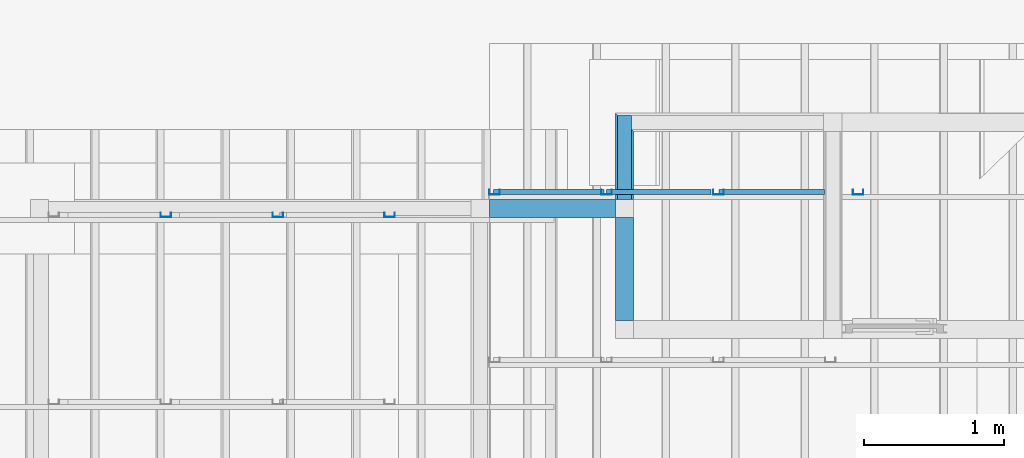
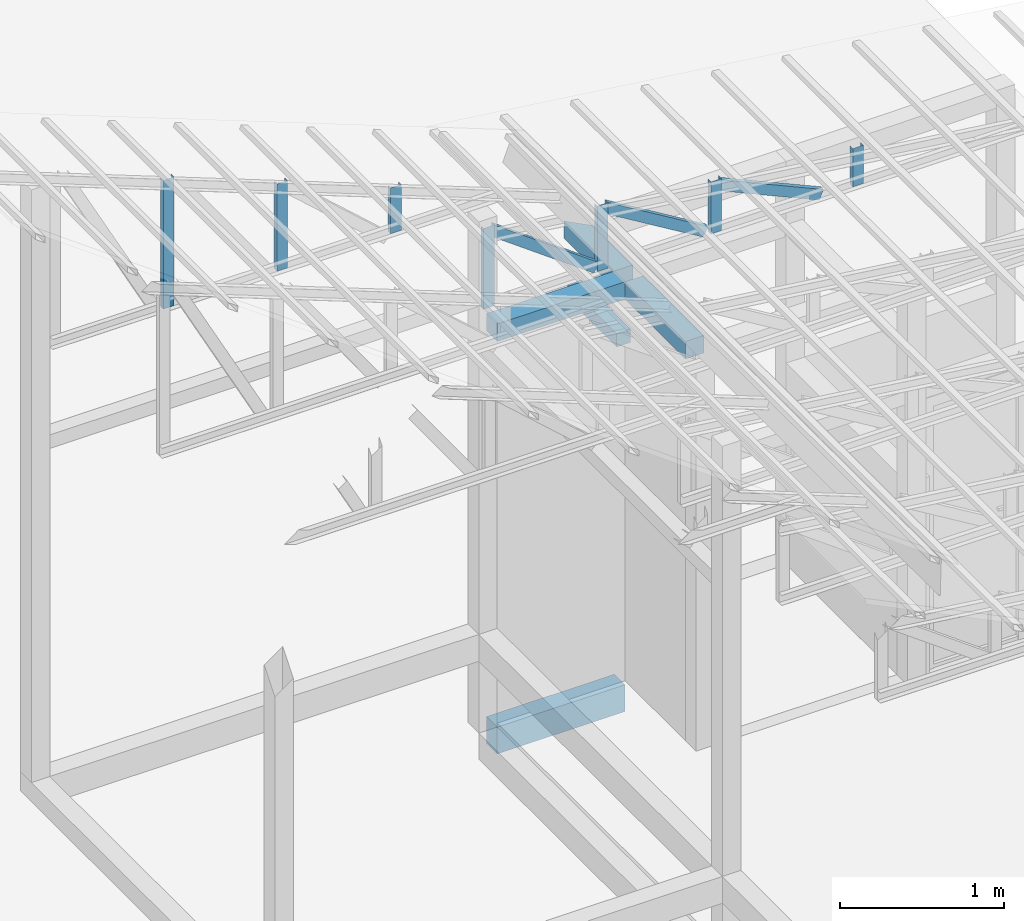
# One storey, part 19 of 22: 10 members, 5 beams, 2 elements without a shape of their own.
"""IFC4 building model written with IfcOpenShell, lengths in millimetres."""

from ifc_helpers import new_model, entity, si_unit, converted_unit, frame, origin_with_axes, origin_2d_with_axis, place, context, subcontext, project, spatial, indexed_curve, rectangle, c_section, outline, extrude, clip, halfspace, material, material_profile, profile_set, profile_usage, type_object, element, aggregate, save


model = new_model("IFC4")

# Units and contexts
model_context = context("Model", 3, precision=1e-05, world=origin_with_axes())
plan_context = context("Plan", 2, precision=1e-05, world=origin_2d_with_axis())
body_context = subcontext(model_context, "Body", "Model", "MODEL_VIEW")
ifc_project = project(units=[si_unit("VOLUMEUNIT", "CUBIC_METRE"), si_unit("LENGTHUNIT", "METRE", prefix="MILLI"), si_unit("AREAUNIT", "SQUARE_METRE"), converted_unit("PLANEANGLEUNIT", "degree", entity("IfcReal", 0.0174532925199433), si_unit("PLANEANGLEUNIT", "RADIAN"), dimensions=[0, 0, 0, 0, 0, 0, 0])], contexts=[model_context, plan_context])

# Site, building, storey
site_placement = place(None, origin_with_axes())
site = spatial("IfcSite", under=ifc_project, at=site_placement)
building_placement = place(site_placement, origin_with_axes())
building = spatial("IfcBuilding", under=site, at=building_placement, Name="2")
storey_placement = place(building_placement, frame((0.0, 0.0, 200.000002980232), z_axis=(0.0, 0.0, 1.0), x_axis=(1.0, 0.0, 0.0)))
storey = spatial("IfcBuildingStorey", under=building, at=storey_placement)

# Beams
ifc_material_1 = material(Name="Concrete")
ifc_material_profile_1 = material_profile(ifc_material_1, outline(indexed_curve([(-65.0, 99.9999923706055), (65.0, 99.9999923706055), (65.0, -99.9999923706055), (-65.0, -99.9999923706055), (-65.0, 99.9999923706055)])))
ifc_profile_set_1 = profile_set([ifc_material_profile_1])
ifc_profile_usage_1 = profile_usage(ifc_profile_set_1, cardinal=2)
beam_type_1 = type_object("IfcBeamType", PredefinedType="BEAM", material=ifc_profile_set_1)
beam_1_placement = place(storey_placement, frame((-3035.00008583069, 17300.0011444092, -200.000066923081), z_axis=(-0.99999999999995, 4.37114096030178e-08, 3.13916473260163e-07), x_axis=(-4.37113882867378e-08, -0.999999999999997, 5.96046589862452e-08)))
element("IfcBeam", 1, at=beam_1_placement, inside=storey, type_object=beam_type_1, material=ifc_profile_usage_1, Name="Beam", PredefinedType="BEAM", context=body_context, shape_type="SweptSolid", body=[
    extrude(outline(indexed_curve([(-65.0, 99.9999923706055), (65.0, 99.9999923706055), (65.0, -99.9999923706055), (-65.0, -99.9999923706055), (-65.0, 99.9999923706055)])), frame((0.0, 100.0, 0.0), z_axis=(0.0, 0.0, 1.0), x_axis=(1.0, 0.0, 0.0)), (0.0, 0.0, 1.0), 899.993908384733),
])
ifc_material_profile_2 = material_profile(ifc_material_1, rectangle(XDim=130.000015258789, YDim=130.000015258789))
ifc_profile_set_2 = profile_set([ifc_material_profile_2])
ifc_profile_usage_2 = profile_usage(ifc_profile_set_2, cardinal=9)
beam_type_2 = type_object("IfcBeamType", Name="Ring", PredefinedType="BEAM", material=ifc_profile_set_2)
beam_2_placement = place(storey_placement, frame((-3034.97314453125, 17979.9995422363, 3000.00028312206), z_axis=(0.0, -0.999999999999997, 7.54978986586412e-08), x_axis=(1.0, 0.0, 0.0)))
element("IfcBeam", 2, at=beam_2_placement, inside=storey, type_object=beam_type_2, material=ifc_profile_usage_2, Name="Beam", context=body_context, shape_type="Clipping", body=[
    clip(extrude(rectangle(XDim=130.000015258789, YDim=130.000015258789), frame((65.0000076293945, -65.0000076293945, 0.0), z_axis=(0.0, 0.0, 1.0), x_axis=(1.0, 0.0, 0.0)), (0.0, 0.0, 1.0), 615.009303022594), halfspace(frame((0.0, -3200.00171661377, -0.0019073486328125), z_axis=(0.707103550434113, 1.12382778638676e-08, -0.707110106945038), x_axis=(1.58933975893178e-08, -1.0, 0.0)), False)),
])
ifc_profile_usage_3 = profile_usage(ifc_profile_set_2, cardinal=9)
beam_3_placement = place(storey_placement, frame((-3034.97314453125, 17364.990234375, 3000.00028312206), z_axis=(-0.999999999999962, -1.94707164287728e-07, 1.94707178498585e-07), x_axis=(1.94707178498587e-07, -0.999999999999974, 1.19209289550778e-07)))
element("IfcBeam", 3, at=beam_3_placement, inside=storey, type_object=beam_type_2, material=ifc_profile_usage_3, Name="Beam", context=body_context, shape_type="SweptSolid", body=[
    extrude(rectangle(XDim=130.000015258789, YDim=130.000015258789), frame((65.0000076293945, -65.0000076293945, 0.0), z_axis=(0.0, 0.0, 1.0), x_axis=(1.0, 0.0, 0.0)), (0.0, 0.0, 1.0), 900.024405784302),
])
ifc_profile_usage_4 = profile_usage(ifc_profile_set_2, cardinal=9)
beam_4_placement = place(storey_placement, frame((-3035.00008583069, 17234.9987030029, 3000.00028312206), z_axis=(0.0, -0.999999999999997, 7.54978986586412e-08), x_axis=(1.0, 0.0, 0.0)))
element("IfcBeam", 4, at=beam_4_placement, inside=storey, type_object=beam_type_2, material=ifc_profile_usage_4, Name="Beam", context=body_context, shape_type="SweptSolid", body=[
    extrude(rectangle(XDim=130.000015258789, YDim=130.000015258789), frame((65.0000076293945, -65.0000076293945, 0.0), z_axis=(0.0, 0.0, 1.0), x_axis=(1.0, 0.0, 0.0)), (0.0, 0.0, 1.0), 734.998722205057),
])

# Assembly, members
assembly_1_placement = place(storey_placement, frame((-1561.45393848419, 6600.0657081604, 3019.63977515697), z_axis=(0.0, 0.0, 1.0), x_axis=(1.0, 0.0, 0.0)))
assembly_1 = element("IfcElementAssembly", 5, at=assembly_1_placement, inside=storey, Name="K1")
ifc_material_2 = material(Name="STEEL")
ifc_material_profile_3 = material_profile(ifc_material_2, c_section(Depth=75.0, Width=35.0, WallThickness=1.0, Girth=1.0, kind="CURVE"))
ifc_profile_set_3 = profile_set([ifc_material_profile_3])
ifc_profile_usage_5 = profile_usage(ifc_profile_set_3, cardinal=9)
member_type = type_object("IfcMemberType", Name="C75", PredefinedType="CHORD", material=ifc_profile_set_3)
member_1_placement = place(assembly_1_placement, frame((-2299.51107501984, 10798.9325523376, 592.46301651001), z_axis=(-8.7422719730052e-08, 3.25841369885875e-07, -0.999999999999943), x_axis=(1.62920684942936e-07, 0.999999999999934, 3.25841369885871e-07)))
member_1 = element("IfcMember", 6, at=member_1_placement, type_object=member_type, material=ifc_profile_usage_5, Name="Member", context=body_context, shape_type="SweptSolid", body=[
    extrude(c_section(Depth=75.0, Width=35.0, WallThickness=1.0, Girth=1.0, kind="CURVE"), frame((17.5, -37.5, 0.0), z_axis=(0.0, 0.0, 1.0), x_axis=(1.0, 0.0, 0.0)), (0.0, 0.0, 1.0), 601.479041515268),
])
ifc_profile_usage_6 = profile_usage(ifc_profile_set_3, cardinal=9)
member_2_placement = place(assembly_1_placement, frame((-1499.51112270355, 10798.9325523376, 479.381561279297), z_axis=(-8.7422719730052e-08, 3.25841369885875e-07, -0.999999999999943), x_axis=(1.62920684942936e-07, 0.999999999999934, 3.25841369885871e-07)))
member_2 = element("IfcMember", 7, at=member_2_placement, type_object=member_type, material=ifc_profile_usage_6, Name="Member", context=body_context, shape_type="SweptSolid", body=[
    extrude(c_section(Depth=75.0, Width=35.0, WallThickness=1.0, Girth=1.0, kind="CURVE"), frame((17.5, -37.5, 0.0), z_axis=(0.0, 0.0, 1.0), x_axis=(1.0, 0.0, 0.0)), (0.0, 0.0, 1.0), 488.397843745656),
])
ifc_profile_usage_7 = profile_usage(ifc_profile_set_3, cardinal=9)
member_3_placement = place(assembly_1_placement, frame((-702.355027198792, 10799.9320030212, 368.052959442139), z_axis=(0.912206913056706, -0.00121979383816088, -0.409728031594797), x_axis=(0.00137145876901944, 0.999999056639273, 7.62981516029096e-05)))
member_3 = element("IfcMember", 8, at=member_3_placement, type_object=member_type, material=ifc_profile_usage_7, Name="Member", context=body_context, shape_type="SweptSolid", body=[
    extrude(c_section(Depth=75.0, Width=35.0, WallThickness=1.0, Girth=1.0, kind="CURVE"), frame((17.5, -37.5, 0.0), z_axis=(0.0, 0.0, 1.0), x_axis=(1.0, 0.0, 0.0)), (0.0, 0.0, 1.0), 791.494517196627),
])
ifc_profile_usage_8 = profile_usage(ifc_profile_set_3, cardinal=9)
member_4_placement = place(assembly_1_placement, frame((299.198031425476, 10798.9325523376, 276.402950286865), z_axis=(-1.50995731473803e-07, 3.25841398307582e-07, -0.999999999999936), x_axis=(1.94707183709383e-07, 0.999999999999928, 3.2584136988587e-07)))
member_4 = element("IfcMember", 9, at=member_4_placement, type_object=member_type, material=ifc_profile_usage_8, Name="Member", context=body_context, shape_type="SweptSolid", body=[
    extrude(c_section(Depth=75.0, Width=35.0, WallThickness=1.0, Girth=1.0, kind="CURVE"), frame((17.5, -37.5, 0.0), z_axis=(0.0, 0.0, 1.0), x_axis=(1.0, 0.0, 0.0)), (0.0, 0.0, 1.0), 285.418990339209),
])
ifc_profile_usage_9 = profile_usage(ifc_profile_set_3, cardinal=9)
member_5_placement = place(assembly_1_placement, frame((-2299.51107501984, 10798.9325523376, 592.46301651001), z_axis=(0.807471586940316, -1.26964538798404e-07, -0.589906464012789), x_axis=(7.54979012640426e-08, 0.999999999999991, -1.1188575399501e-07)))
member_5 = element("IfcMember", 10, at=member_5_placement, type_object=member_type, material=ifc_profile_usage_9, Name="Member", context=body_context, shape_type="SweptSolid", body=[
    extrude(c_section(Depth=75.0, Width=35.0, WallThickness=1.0, Girth=1.0, kind="CURVE"), frame((17.5, -37.5, 0.0), z_axis=(0.0, 0.0, 1.0), x_axis=(1.0, 0.0, 0.0)), (0.0, 0.0, 1.0), 921.685377112707),
])
ifc_profile_usage_10 = profile_usage(ifc_profile_set_3, cardinal=9)
member_6_placement = place(assembly_1_placement, frame((-1499.51112270355, 10798.9325523376, 479.381561279297), z_axis=(0.855801528545197, -4.23314648434558e-08, -0.517304304775924), x_axis=(7.5497901264043e-08, 0.999999999999996, 4.30689546249139e-08)))
member_6 = element("IfcMember", 11, at=member_6_placement, type_object=member_type, material=ifc_profile_usage_10, Name="Member", context=body_context, shape_type="SweptSolid", body=[
    extrude(c_section(Depth=75.0, Width=35.0, WallThickness=1.0, Girth=1.0, kind="CURVE"), frame((17.5, -37.5, 0.0), z_axis=(0.0, 0.0, 1.0), x_axis=(1.0, 0.0, 0.0)), (0.0, 0.0, 1.0), 826.976096113964),
])
ifc_profile_usage_11 = profile_usage(ifc_profile_set_3, cardinal=9)
member_7_placement = place(assembly_1_placement, frame((-699.511170387268, 10798.9325523376, 377.824306488037), z_axis=(-8.7422719730052e-08, 3.25841369885875e-07, -0.999999999999943), x_axis=(1.62920684942936e-07, 0.999999999999934, 3.25841369885871e-07)))
member_7 = element("IfcMember", 12, at=member_7_placement, type_object=member_type, material=ifc_profile_usage_11, Name="Member", context=body_context, shape_type="SweptSolid", body=[
    extrude(c_section(Depth=75.0, Width=35.0, WallThickness=1.0, Girth=1.0, kind="CURVE"), frame((17.5, -37.5, 0.0), z_axis=(0.0, 0.0, 1.0), x_axis=(1.0, 0.0, 0.0)), (0.0, 0.0, 1.0), 386.840589191612),
])
aggregate(assembly_1, [member_1, member_2, member_3, member_4, member_5, member_6, member_7])

assembly_2_placement = place(storey_placement, frame((-3938.51041793823, 5099.00283813477, 3935.3459328413), z_axis=(0.0, 0.0, 1.0), x_axis=(1.0, 0.0, 0.0)))
assembly_2 = element("IfcElementAssembly", 13, at=assembly_2_placement, inside=storey, Name="2")
ifc_profile_usage_12 = profile_usage(ifc_profile_set_3, cardinal=1)
member_8_placement = place(assembly_2_placement, frame((-1546.51069641113, 12170.9976196289, 648.419380187988), z_axis=(-8.74227410463377e-08, -1.50995830949794e-07, -0.999999999999985), x_axis=(-3.13916473260159e-07, 0.999999999999939, -1.50995802528077e-07)))
member_8 = element("IfcMember", 14, at=member_8_placement, type_object=member_type, material=ifc_profile_usage_12, Name="Member", context=body_context, shape_type="SweptSolid", body=[
    extrude(c_section(Depth=75.0, Width=35.0, WallThickness=1.0, Girth=1.0, kind="CURVE"), frame((-17.5, 37.5, 0.0), z_axis=(0.0, 0.0, 1.0), x_axis=(1.0, 0.0, 0.0)), (0.0, 0.0, 1.0), 649.773129888493),
])
ifc_profile_usage_13 = profile_usage(ifc_profile_set_3, cardinal=1)
member_9_placement = place(assembly_2_placement, frame((-2346.510887146, 12170.9976196289, 957.056522369385), z_axis=(-8.74227410463377e-08, -1.50995830949794e-07, -0.999999999999985), x_axis=(-3.13916473260159e-07, 0.999999999999939, -1.50995802528077e-07)))
member_9 = element("IfcMember", 15, at=member_9_placement, type_object=member_type, material=ifc_profile_usage_13, Name="Member", context=body_context, shape_type="SweptSolid", body=[
    extrude(c_section(Depth=75.0, Width=35.0, WallThickness=1.0, Girth=1.0, kind="CURVE"), frame((-17.5, 37.5, 0.0), z_axis=(0.0, 0.0, 1.0), x_axis=(1.0, 0.0, 0.0)), (0.0, 0.0, 1.0), 958.410273794281),
])
ifc_profile_usage_14 = profile_usage(ifc_profile_set_3, cardinal=1)
member_10_placement = place(assembly_2_placement, frame((-746.51050567627, 12170.9976196289, 339.939117431641), z_axis=(-8.74227410463377e-08, -1.50995830949794e-07, -0.999999999999985), x_axis=(-3.13916473260159e-07, 0.999999999999939, -1.50995802528077e-07)))
member_10 = element("IfcMember", 16, at=member_10_placement, type_object=member_type, material=ifc_profile_usage_14, Name="Member", context=body_context, shape_type="SweptSolid", body=[
    extrude(c_section(Depth=75.0, Width=35.0, WallThickness=1.0, Girth=1.0, kind="CURVE"), frame((-17.5, 37.5, 0.0), z_axis=(0.0, 0.0, 1.0), x_axis=(1.0, 0.0, 0.0)), (0.0, 0.0, 1.0), 341.292854350017),
])
aggregate(assembly_2, [member_8, member_9, member_10])

# Beam
ifc_material_profile_4 = material_profile(ifc_material_1, rectangle(XDim=100.0, YDim=100.0))
ifc_profile_set_4 = profile_set([ifc_material_profile_4])
ifc_profile_usage_15 = profile_usage(ifc_profile_set_4, cardinal=2)
beam_type_3 = type_object("IfcBeamType", PredefinedType="BEAM", material=ifc_profile_set_4)
beam_5_placement = place(storey_placement, frame((-2970.00002861023, 17965.0001525879, 2430.00464141369), z_axis=(-1.8482070629397e-07, -0.999999999995043, -3.14315298054032e-06), x_axis=(0.999999999999983, -1.84820706294883e-07, -1.46446389222155e-14)))
element("IfcBeam", 17, at=beam_5_placement, inside=storey, type_object=beam_type_3, material=ifc_profile_usage_15, Name="Beam", PredefinedType="BEAM", context=body_context, shape_type="SweptSolid", body=[
    extrude(rectangle(XDim=100.0, YDim=100.0), frame((0.0, 50.0, 0.0), z_axis=(0.0, 0.0, 1.0), x_axis=(1.0, 0.0, 0.0)), (0.0, 0.0, 1.0), 600.000384452915),
])

save(model, "model.ifc")
